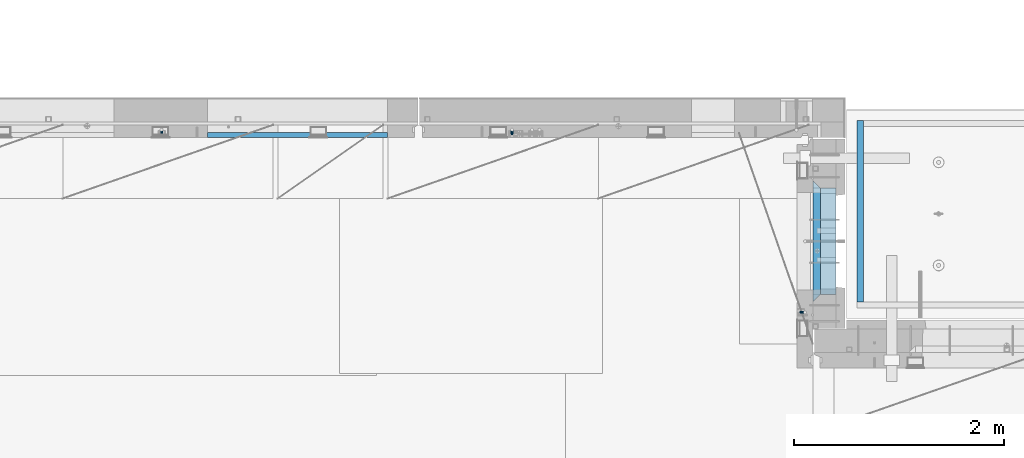
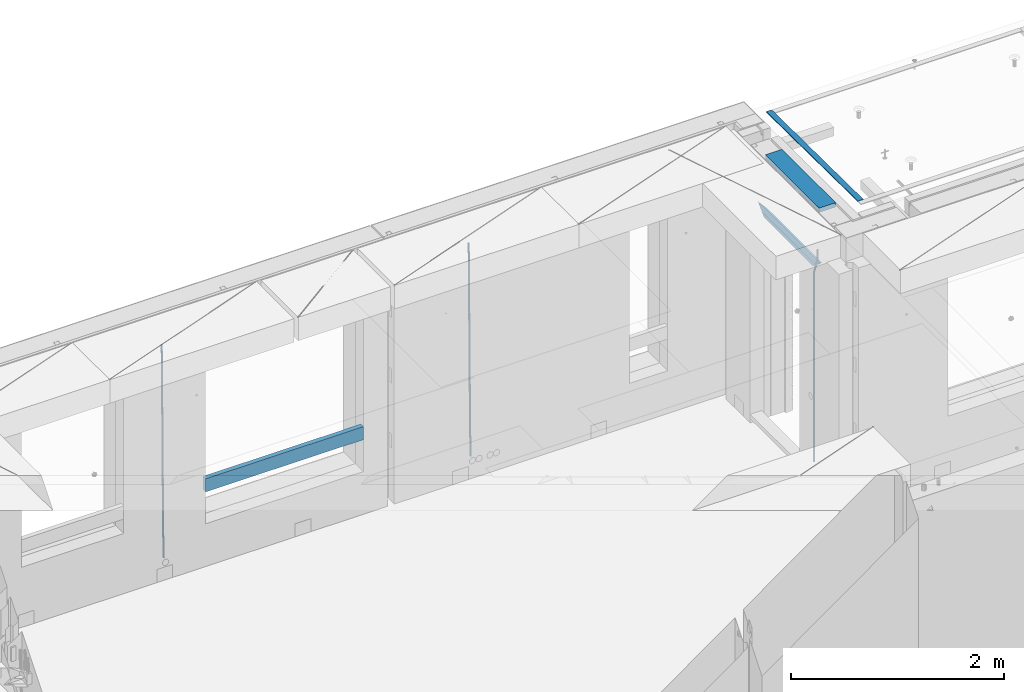
# One storey, part 109 of 325: 8 beams, 4 elements without a shape of their own.
"""IFC2X3 building model written with IfcOpenShell, lengths in millimetres."""

from ifc_helpers import new_model, si_unit, frame, origin_with_axes, place, context, subcontext, project, spatial, faceted_brep, material, type_object, element, aggregate, save


model = new_model("IFC2X3")

# Units and contexts
model_context = context("Model", 3, precision=1e-05, world=origin_with_axes())
body_context = subcontext(model_context, "Body", "Model", "MODEL_VIEW")
ifc_project = project(units=[si_unit("LENGTHUNIT", "METRE", prefix="MILLI"), si_unit("AREAUNIT", "SQUARE_METRE"), si_unit("VOLUMEUNIT", "CUBIC_METRE"), si_unit("MASSUNIT", "GRAM", prefix="KILO"), si_unit("TIMEUNIT", "SECOND"), si_unit("PLANEANGLEUNIT", "RADIAN"), si_unit("SOLIDANGLEUNIT", "STERADIAN"), si_unit("THERMODYNAMICTEMPERATUREUNIT", "DEGREE_CELSIUS"), si_unit("LUMINOUSINTENSITYUNIT", "LUMEN")], contexts=[model_context])

# Site, building, storey
site_placement = place(None, origin_with_axes())
site = spatial("IfcSite", under=ifc_project, at=site_placement, CompositionType="ELEMENT")
building_placement = place(site_placement, origin_with_axes())
building = spatial("IfcBuilding", under=site, at=building_placement, CompositionType="ELEMENT")
storey_placement = place(building_placement, origin_with_axes())
storey = spatial("IfcBuildingStorey", under=building, at=storey_placement, Name="1", CompositionType="ELEMENT", Elevation=0.0)

# Assembly, beams
assembly_1_placement = place(storey_placement, origin_with_axes())
assembly_1 = element("IfcElementAssembly", 1, at=assembly_1_placement, inside=storey, AssemblyPlace="NOTDEFINED", PredefinedType="REINFORCEMENT_UNIT")
ifc_material_1 = material(Name="CONCRETE/C25/30")
beam_type_1 = type_object("IfcBeamType", PredefinedType="NOTDEFINED")
beam_1_placement = place(assembly_1_placement, frame((31494.9951872276, 21060.0002716511, 84140.0), z_axis=(0.0, 0.0, -1.0), x_axis=(0.0, 1.0, 0.0)))
beam_1 = element("IfcBeam", 2, at=beam_1_placement, type_object=beam_type_1, material=ifc_material_1, Name="SK", context=body_context, shape_type="Brep", body=[
    faceted_brep([(70.0000000000164, -35.0, 35.0), (70.0000000000164, 35.0, 35.0), (0.0, -35.0, -35.0), (1079.99961853027, 35.0, 35.0), (1149.99961853027, -35.0, -35.0), (1079.99961853027, -35.0, 35.0)], [[[0, 1, 2]], [[2, 1, 3, 4]], [[0, 2, 4, 5]], [[1, 0, 5, 3]], [[4, 3, 5]]]),
])
beam_type_2 = type_object("IfcBeamType", PredefinedType="NOTDEFINED")
beam_2_placement = place(assembly_1_placement, frame((31494.9951872276, 21130.0002716511, 84080.0), z_axis=(0.0, 0.0, -1.0), x_axis=(0.0, 1.0, 0.0)))
beam_2 = element("IfcBeam", 3, at=beam_2_placement, type_object=beam_type_2, material=ifc_material_1, Name="SK", context=body_context, shape_type="Brep", body=[
    faceted_brep([(0.0, -35.0, -25.0), (43.8457723764295, -35.0, 18.8461538461561), (45.6406441713007, 35.0, 20.6410256410309), (0.0, 35.0, -25.0), (1009.99961853027, 35.0, -25.0), (1009.99961853027, -35.0, -25.0), (966.153464684117, -35.0, 18.8461538461561), (964.358592889246, 35.0, 20.6410256410309)], [[[0, 1, 2, 3]], [[0, 3, 4, 5]], [[1, 0, 5, 6]], [[6, 7, 2, 1]], [[3, 2, 7, 4]], [[6, 5, 4, 7]]]),
])
ifc_material_2 = material()
beam_type_3 = type_object("IfcBeamType", Name="D20", PredefinedType="NOTDEFINED")
beam_3_placement = place(assembly_1_placement, frame((31384.9951872298, 20959.9999999916, 84407.5), z_axis=(-0.999999913638316, 0.000415599999849952, 0.0), x_axis=(0.0, 0.0, -1.0)))
beam_3 = element("IfcBeam", 4, at=beam_3_placement, type_object=beam_type_3, material=ifc_material_2, Name="JM20", ObjectType="D20", context=body_context, shape_type="Brep", body=[
    faceted_brep([(0.0, -10.0, 0.0), (-4.19531716033816e-08, -7.07106781186667, -7.07106781187031), (113.248091332178, -7.0710684840451, -7.0710678117357), (113.248091314759, -10.0000006713562, -2.51020537689328e-10), (0.0, 0.0, -10.0), (113.248091374131, -6.72178430249915e-07, -9.99999999986903), (4.196772351861e-08, 7.07106781186303, -7.07106781186667), (113.248091416113, 7.07106713968824, -7.07106781173934), (0.0, 10.0, 0.0), (113.248091433488, 9.99999932782521, 1.30967237055302e-10), (4.196772351861e-08, 7.07106781185939, 7.07106781185939), (113.248091416113, 7.0710671396846, 7.071067811994), (0.0, 0.0, 10.0), (113.248091374131, -6.72174792271107e-07, 10.0000000001273), (-4.19531716033816e-08, -7.07106781187031, 7.07106781185939), (113.248091332178, -7.0710684840451, 7.071067811994), (130.699843527167, -7.06993249763036, -4.33745683788584), (128.538066582521, -9.99900540317321, 2.39499413731755), (131.594536475241, 0.00119355250353692, -7.12624594330919), (130.698046432328, 7.07220300913468, -4.33773834422391), (128.535525107087, 10.0009944322555, 2.39459602660281), (126.373748162892, 7.07192152754578, 9.1270470011732), (125.479055214906, 0.000795477419160306, 11.9158361066184), (126.37554525779, -7.07021397921199, 9.12732850753673), (240.336258550378, -7.05529970173666, 30.8729495437874), (238.174481606227, -9.98437260450009, 37.6054005176375), (241.230951498423, 0.0158263482953771, 28.0841604381058), (240.334461455612, 7.0868358050102, 30.8726680369582), (238.171940130502, 10.0156272283348, 37.6050024077231), (236.010163186409, 7.08655432384694, 44.3374533824244), (235.115470238379, 0.0154282738185429, 47.1262424881097), (236.011960281176, -7.05558118289991, 44.3377348892536), (253.461915329972, -7.05444528127919, 32.9289287376414), (253.46191532613, -9.98337746617108, 39.9999965521893), (253.461915339081, 0.0166225284556276, 29.9999965443676), (253.461915348205, 7.08769034247234, 32.9289287273205), (253.461915352003, 10.0166225357716, 39.9999965370152), (253.461915348293, 7.08769035281148, 47.0710643509774), (253.461915339183, 0.0166225430875784, 49.999996544273), (253.46191533003, -7.05444527093641, 47.0710643613093), (2417.50000002384, -7.0544364694706, 32.9289287374122), (2417.5000000337, -9.98336865393321, 39.9999965507959), (2417.49999999997, 0.0166313408753922, 29.9999965456082), (2417.49999997609, 7.08769915426274, 32.9289287300708), (2417.4999999662, 10.0166313460668, 39.9999965404204), (2417.49999997608, 7.08769916160054, 47.0710643538114), (2417.49999999994, 0.0166313512581837, 49.9999965456154), (2417.50000002382, -7.05443646212916, 47.0710643611455)], [[[0, 1, 2, 3]], [[1, 4, 5, 2]], [[4, 6, 7, 5]], [[6, 8, 9, 7]], [[8, 10, 11, 9]], [[10, 12, 13, 11]], [[12, 14, 15, 13]], [[14, 0, 3, 15]], [[14, 12, 10, 8, 6, 4, 1, 0]], [[3, 2, 16, 17]], [[2, 5, 18, 16]], [[5, 7, 19, 18]], [[7, 9, 20, 19]], [[9, 11, 21, 20]], [[11, 13, 22, 21]], [[13, 15, 23, 22]], [[15, 3, 17, 23]], [[17, 16, 24, 25]], [[16, 18, 26, 24]], [[18, 19, 27, 26]], [[19, 20, 28, 27]], [[20, 21, 29, 28]], [[21, 22, 30, 29]], [[22, 23, 31, 30]], [[23, 17, 25, 31]], [[25, 24, 32, 33]], [[24, 26, 34, 32]], [[26, 27, 35, 34]], [[27, 28, 36, 35]], [[28, 29, 37, 36]], [[29, 30, 38, 37]], [[30, 31, 39, 38]], [[31, 25, 33, 39]], [[33, 32, 40, 41]], [[32, 34, 42, 40]], [[34, 35, 43, 42]], [[35, 36, 44, 43]], [[36, 37, 45, 44]], [[37, 38, 46, 45]], [[38, 39, 47, 46]], [[39, 33, 41, 47]], [[42, 43, 44, 45, 46, 47, 41, 40]]]),
])

# Assembly, beam
assembly_2_placement = place(storey_placement, origin_with_axes())
assembly_2 = element("IfcElementAssembly", 5, at=assembly_2_placement, inside=storey, AssemblyPlace="NOTDEFINED", PredefinedType="REINFORCEMENT_UNIT")
beam_4_placement = place(assembly_2_placement, frame((28600.0000000039, 22654.9999977209, 81990.0), z_axis=(-0.000205762999925498, 0.999642804629538, -0.0267249099901004), x_axis=(4.30000201928125e-08, 0.0267249099948059, 0.999642825806181)))
beam_4 = element("IfcBeam", 6, at=beam_4_placement, type_object=beam_type_3, material=ifc_material_2, Name="JM20", ObjectType="D20", context=body_context, shape_type="Brep", body=[
    faceted_brep([(0.0, -10.0, 0.0), (-4.19531716033816e-08, -7.07106781186667, -7.07106781187031), (60.4266690400545, -7.0710677960451, -7.07106780570757), (60.4266690441291, -9.99999998418934, 6.15546014159918e-09), (0.0, 0.0, -10.0), (60.426669036824, 1.58106558956206e-08, -9.99999999384454), (4.196772351861e-08, 7.07106781186303, -7.07106781186667), (60.4266690363438, 7.07106782768096, -7.07106780570757), (0.0, 10.0, 0.0), (60.4266690388904, 10.0000000158179, 6.15182216279209e-09), (4.196772351861e-08, 7.07106781185939, 7.07106781185939), (60.4266690429649, 7.07106782768096, 7.07106781802577), (0.0, 0.0, 10.0), (60.4266690461809, 1.58179318532348e-08, 10.0000000061555), (-4.19531716033816e-08, -7.07106781187031, 7.07106781185939), (60.4266690466611, -7.07106779605238, 7.07106781802213), (61.0378400410118, -7.07106779588503, -7.07106780564936), (60.991799419251, -9.99999998403655, 6.21366780251265e-09), (61.0569027789461, 1.5985278878361e-08, -9.99999999378269), (61.0378209396877, 7.07106782784831, -7.07106780564936), (60.9917724058905, 10.0000000159635, 6.21366780251265e-09), (60.9457317841297, 7.07106782781193, 7.0710678180767), (60.9266690461809, 1.59488990902901e-08, 10.0000000062028), (60.9457508854539, -7.07106779591413, 7.0710678180767), (61.6489592143771, -7.07106614513759, -7.06310863441468), (61.5568818710308, -9.9999984576425, 0.00735959856683621), (61.6870830769039, 1.71821739058942e-06, -9.99179257185824), (61.6489210170112, 7.07106947854481, -7.06310888312146), (61.556827851804, 10.0000015422847, 0.00735924683976918), (61.4647505084577, 7.07106922979438, 7.07782747982128), (61.4266266459163, 1.36643211590126e-06, 10.0065114172685), (61.464788705809, -7.07106639389531, 7.07782772852806), (176.543135720174, -7.07075579406956, -5.56673531796696), (176.451058376813, -9.99968810657447, 1.50373291501455), (176.581259582701, 0.000312069292704109, -8.49541925541052), (176.543097522794, 7.07137982961285, -5.56673556667374), (176.451004357587, 10.00031189336, 1.50373256329476), (176.35892701424, 7.07137958085514, 8.57420079627263), (176.320803151699, 0.000311717507429421, 11.5028847337162), (176.358965211621, -7.07075604281999, 8.57420104497578), (177.098753836006, -7.07075429323595, -5.55949898843028), (176.98362511232, -9.99968666800123, 1.510669025065), (177.146421932586, 0.000313595905026887, -8.48805862247536), (177.098706077581, 7.07138133041735, -5.55949936166144), (176.983557571715, 10.0003133318824, 1.51066849724157), (176.868428848029, 7.07138095712435, 8.58083651073321), (176.820760751449, 0.000313067976094317, 11.5093961447819), (176.868476606425, -7.07075466652896, 8.58083688396073), (177.654312950661, -7.07075204110879, -5.54863964998367), (177.516135294456, -9.99968450931192, 1.52107783331303), (177.711524267797, 0.000315886711177882, -8.47701274570863), (177.654255632195, 7.07138358250813, -5.54864021007961), (177.516054233929, 10.0003154905207, 1.5210770412159), (177.377876577739, 7.0713830223176, 8.59079452451624), (177.320665260588, 0.000315094497636892, 11.5191676202448), (177.377933896176, -7.07075260129932, 8.59079508461218), (299.436796249574, -7.07025836271714, -3.1681962331204), (299.298618593355, -9.99919083092027, 3.90152125031091), (299.494007566798, 0.000809565110102994, -6.09656932889993), (299.436738931283, 7.07187726089978, -3.16819679320906), (299.298537533061, 10.0008091689197, 3.90152045822106), (299.160359876842, 7.07187670072017, 10.9712379416487), (299.103148559603, 0.000808772889286047, 13.8996110374392), (299.160417195119, -7.07025892290039, 10.9712385017483), (299.98743051647, -7.07025613056248, -3.15743315966392), (299.971788958996, -9.99918809853989, 3.91467979818117), (299.993912075952, 0.000811591617093654, -6.08679785393178), (299.987423933868, 7.07187949325817, -3.1574327280432), (299.971753863239, 10.0008119014747, 3.91467990454839), (299.95611230444, 7.07187992653053, 10.9867922621015), (299.949630744944, 0.000812204350950196, 13.9161569563694), (299.956118887014, -7.07025569729012, 10.9867918304735), (300.538107039494, -7.07025785017686, -3.16575821840888), (300.644985195438, -9.99919020432935, 3.90450175465594), (300.493854948218, 0.000810030429420294, -6.09435592770024), (300.538151196495, 7.071877773491, -3.16575855385963), (300.645047642858, 10.0008097955724, 3.90450128024895), (300.751925798773, 7.07187744142357, 10.9747612533101), (300.796177890064, 0.000809560813650023, 13.9033589625978), (300.751881641787, -7.07025818224065, 10.9747615887682), (2293.36490490142, -7.07648090940347, -33.2930642912361), (2293.47178305736, -10.0054132635523, -26.2228043181785), (2293.32065281013, -0.00541302880083094, -36.2216620005347), (2293.36494905842, 7.06565471425711, -33.2930646266868), (2293.47184550477, 9.99458673634581, -26.2228047925819), (2293.57872366071, 7.06565438219332, -19.1525448195243), (2293.62297575199, -0.00541349841296324, -16.2239471102366), (2293.57867950371, -7.0764812414709, -19.1525444840736), (2294.0658245362, -7.07648309818615, -33.3036607065333), (2294.05312277409, -10.0054150789219, -26.2315929392535), (2294.10928714235, -0.00541549149056664, -36.2335844756526), (2294.15805078732, 7.06565223761572, -33.3050546393533), (2294.18355038921, 9.99458451388637, -26.2335642579346), (2294.17084862708, 7.06565253314329, -19.1614964906439), (2294.12738602093, -0.00541507354500936, -16.2315727215355), (2294.07862237596, -7.07648280265857, -19.1601025578348), (2294.76670261032, -7.08562269121467, -33.294332712383), (2294.63442802057, -10.0129954178956, -26.2238563411993), (2294.89787471293, -0.0156988342423574, -36.2230891548279), (2294.95110548967, 7.05531064255774, -33.2944998654275), (2294.89521307347, 9.98530428734011, -26.2240927312887), (2294.76293848372, 7.0579315606592, -19.1536163601049), (2294.63176638114, -0.0119922963167483, -16.2248599176673), (2294.57853560438, -7.08300177311321, -19.1534492070678), (2316.52657204497, -7.36937582653991, -33.0047303660212), (2316.39429745522, -10.2967485532172, -25.9342539948302), (2316.65774414754, -0.299451969567599, -35.9334868084661), (2316.7109749243, 6.7715575072325, -33.0048975190657), (2316.65508250811, 9.70155115201487, -25.9344903849269), (2316.52280791836, 6.7741784253376, -18.8640140137468), (2316.39163581574, -0.295745431634714, -15.9352575713092), (2316.33840503903, -7.36675490843481, -18.863846860706), (2317.16202064224, -7.37766220584308, -32.9962731735213), (2317.05438744847, -10.3053562613532, -25.9254688497131), (2317.23607125619, -0.306993473008333, -35.925789846493), (2317.23316144495, 6.76474808850253, -32.9979477328052), (2317.15499573652, 9.6950321815566, -25.9278370341635), (2317.04736254275, 6.7673381260538, -18.8570327103698), (2316.97331192881, -0.303330606784584, -15.9275160373909), (2316.97622174003, -7.37507216829545, -18.8553581510787), (2317.79752306276, -7.37578610372293, -32.9880110666527), (2317.71453320107, -10.3033876998124, -25.9168792378296), (2317.81444760226, -0.305295583297266, -35.918287695793), (2317.75539265381, 6.76628640723357, -32.9911928173897), (2317.65495180529, 9.69652304524061, -25.9213789128698), (2317.5719619436, 6.76892144914746, -18.8502470840467), (2317.55503740412, -0.301569071270933, -15.9199704549137), (2317.61409235255, -7.3731510618054, -18.847065333317), (2417.8183084176, -7.07752398473531, -31.6906369377139), (2417.73531855589, -10.0051255808248, -24.6195051088798), (2417.83523295709, -0.007033464313281, -34.6209135668432), (2417.77617800863, 7.06454852621755, -31.6938186884508), (2417.67573716014, 9.99478516423187, -24.6240047839383), (2417.59274729842, 7.06718356813872, -17.5528729551006), (2417.57582275895, -0.00330695228694822, -14.6225963259749), (2417.6348777074, -7.07488894281778, -17.5496912043673)], [[[0, 1, 2, 3]], [[1, 4, 5, 2]], [[4, 6, 7, 5]], [[6, 8, 9, 7]], [[8, 10, 11, 9]], [[10, 12, 13, 11]], [[12, 14, 15, 13]], [[14, 0, 3, 15]], [[14, 12, 10, 8, 6, 4, 1, 0]], [[3, 2, 16, 17]], [[2, 5, 18, 16]], [[5, 7, 19, 18]], [[7, 9, 20, 19]], [[9, 11, 21, 20]], [[11, 13, 22, 21]], [[13, 15, 23, 22]], [[15, 3, 17, 23]], [[17, 16, 24, 25]], [[16, 18, 26, 24]], [[18, 19, 27, 26]], [[19, 20, 28, 27]], [[20, 21, 29, 28]], [[21, 22, 30, 29]], [[22, 23, 31, 30]], [[23, 17, 25, 31]], [[25, 24, 32, 33]], [[24, 26, 34, 32]], [[26, 27, 35, 34]], [[27, 28, 36, 35]], [[28, 29, 37, 36]], [[29, 30, 38, 37]], [[30, 31, 39, 38]], [[31, 25, 33, 39]], [[33, 32, 40, 41]], [[32, 34, 42, 40]], [[34, 35, 43, 42]], [[35, 36, 44, 43]], [[36, 37, 45, 44]], [[37, 38, 46, 45]], [[38, 39, 47, 46]], [[39, 33, 41, 47]], [[41, 40, 48, 49]], [[40, 42, 50, 48]], [[42, 43, 51, 50]], [[43, 44, 52, 51]], [[44, 45, 53, 52]], [[45, 46, 54, 53]], [[46, 47, 55, 54]], [[47, 41, 49, 55]], [[49, 48, 56, 57]], [[48, 50, 58, 56]], [[50, 51, 59, 58]], [[51, 52, 60, 59]], [[52, 53, 61, 60]], [[53, 54, 62, 61]], [[54, 55, 63, 62]], [[55, 49, 57, 63]], [[57, 56, 64, 65]], [[56, 58, 66, 64]], [[58, 59, 67, 66]], [[59, 60, 68, 67]], [[60, 61, 69, 68]], [[61, 62, 70, 69]], [[62, 63, 71, 70]], [[63, 57, 65, 71]], [[65, 64, 72, 73]], [[64, 66, 74, 72]], [[66, 67, 75, 74]], [[67, 68, 76, 75]], [[68, 69, 77, 76]], [[69, 70, 78, 77]], [[70, 71, 79, 78]], [[71, 65, 73, 79]], [[73, 72, 80, 81]], [[72, 74, 82, 80]], [[74, 75, 83, 82]], [[75, 76, 84, 83]], [[76, 77, 85, 84]], [[77, 78, 86, 85]], [[78, 79, 87, 86]], [[79, 73, 81, 87]], [[81, 80, 88, 89]], [[80, 82, 90, 88]], [[82, 83, 91, 90]], [[83, 84, 92, 91]], [[84, 85, 93, 92]], [[85, 86, 94, 93]], [[86, 87, 95, 94]], [[87, 81, 89, 95]], [[89, 88, 96, 97]], [[88, 90, 98, 96]], [[90, 91, 99, 98]], [[91, 92, 100, 99]], [[92, 93, 101, 100]], [[93, 94, 102, 101]], [[94, 95, 103, 102]], [[95, 89, 97, 103]], [[97, 96, 104, 105]], [[96, 98, 106, 104]], [[98, 99, 107, 106]], [[99, 100, 108, 107]], [[100, 101, 109, 108]], [[101, 102, 110, 109]], [[102, 103, 111, 110]], [[103, 97, 105, 111]], [[105, 104, 112, 113]], [[104, 106, 114, 112]], [[106, 107, 115, 114]], [[107, 108, 116, 115]], [[108, 109, 117, 116]], [[109, 110, 118, 117]], [[110, 111, 119, 118]], [[111, 105, 113, 119]], [[113, 112, 120, 121]], [[112, 114, 122, 120]], [[114, 115, 123, 122]], [[115, 116, 124, 123]], [[116, 117, 125, 124]], [[117, 118, 126, 125]], [[118, 119, 127, 126]], [[119, 113, 121, 127]], [[121, 120, 128, 129]], [[120, 122, 130, 128]], [[122, 123, 131, 130]], [[123, 124, 132, 131]], [[124, 125, 133, 132]], [[125, 126, 134, 133]], [[126, 127, 135, 134]], [[127, 121, 129, 135]], [[130, 131, 132, 133, 134, 135, 129, 128]]]),
])
aggregate(assembly_2, [beam_4])

# Assembly, beams
assembly_3_placement = place(storey_placement, origin_with_axes())
assembly_3 = element("IfcElementAssembly", 7, at=assembly_3_placement, inside=storey, AssemblyPlace="NOTDEFINED", PredefinedType="REINFORCEMENT_UNIT")
beam_5_placement = place(assembly_3_placement, frame((25270.0000000039, 22654.999995444, 81990.0), z_axis=(-0.000205762999925498, 0.999642804629538, -0.0267249099901004), x_axis=(4.30000201928125e-08, 0.0267249099948059, 0.999642825806181)))
beam_5 = element("IfcBeam", 8, at=beam_5_placement, type_object=beam_type_3, material=ifc_material_2, Name="JM20", ObjectType="D20", context=body_context, shape_type="Brep", body=[
    faceted_brep([(0.0, -10.0, 0.0), (-4.19531716033816e-08, -7.07106781186667, -7.07106781187031), (60.4266690400545, -7.0710677960451, -7.07106780570757), (60.4266690441291, -9.99999998418934, 6.15546014159918e-09), (0.0, 0.0, -10.0), (60.426669036824, 1.58106558956206e-08, -9.99999999384454), (4.196772351861e-08, 7.07106781186303, -7.07106781186667), (60.4266690363438, 7.07106782768096, -7.07106780570757), (0.0, 10.0, 0.0), (60.4266690388904, 10.0000000158179, 6.15182216279209e-09), (4.196772351861e-08, 7.07106781185939, 7.07106781185939), (60.4266690429649, 7.07106782768096, 7.07106781802577), (0.0, 0.0, 10.0), (60.4266690461809, 1.58179318532348e-08, 10.0000000061555), (-4.19531716033816e-08, -7.07106781187031, 7.07106781185939), (60.4266690466611, -7.07106779605238, 7.07106781802213), (61.0378400410118, -7.07106779588503, -7.07106780564936), (60.991799419251, -9.99999998403655, 6.21366780251265e-09), (61.0569027789461, 1.5985278878361e-08, -9.99999999378269), (61.0378209396877, 7.07106782784831, -7.07106780564936), (60.9917724058905, 10.0000000159635, 6.21366780251265e-09), (60.9457317841297, 7.07106782781193, 7.0710678180767), (60.9266690461809, 1.59488990902901e-08, 10.0000000062028), (60.9457508854539, -7.07106779591413, 7.0710678180767), (61.6489592143771, -7.07106614513759, -7.06310863441468), (61.5568818710308, -9.9999984576425, 0.00735959856683621), (61.6870830769039, 1.71821739058942e-06, -9.99179257185824), (61.6489210170112, 7.07106947854481, -7.06310888312146), (61.556827851804, 10.0000015422847, 0.00735924683976918), (61.4647505084577, 7.07106922979438, 7.07782747982128), (61.4266266459163, 1.36643211590126e-06, 10.0065114172685), (61.464788705809, -7.07106639389531, 7.07782772852806), (176.543135720174, -7.07075579406956, -5.56673531796696), (176.451058376813, -9.99968810657447, 1.50373291501455), (176.581259582701, 0.000312069292704109, -8.49541925541052), (176.543097522794, 7.07137982961285, -5.56673556667374), (176.451004357587, 10.00031189336, 1.50373256329476), (176.35892701424, 7.07137958085514, 8.57420079627263), (176.320803151699, 0.000311717507429421, 11.5028847337162), (176.358965211621, -7.07075604281999, 8.57420104497578), (177.098753836006, -7.07075429323595, -5.55949898843028), (176.98362511232, -9.99968666800123, 1.510669025065), (177.146421932586, 0.000313595905026887, -8.48805862247536), (177.098706077581, 7.07138133041735, -5.55949936166144), (176.983557571715, 10.0003133318824, 1.51066849724157), (176.868428848029, 7.07138095712435, 8.58083651073321), (176.820760751449, 0.000313067976094317, 11.5093961447819), (176.868476606425, -7.07075466652896, 8.58083688396073), (177.654312950661, -7.07075204110879, -5.54863964998367), (177.516135294456, -9.99968450931192, 1.52107783331303), (177.711524267797, 0.000315886711177882, -8.47701274570863), (177.654255632195, 7.07138358250813, -5.54864021007961), (177.516054233929, 10.0003154905207, 1.5210770412159), (177.377876577739, 7.0713830223176, 8.59079452451624), (177.320665260588, 0.000315094497636892, 11.5191676202448), (177.377933896176, -7.07075260129932, 8.59079508461218), (299.436796249574, -7.07025836271714, -3.1681962331204), (299.298618593355, -9.99919083092027, 3.90152125031091), (299.494007566798, 0.000809565110102994, -6.09656932889993), (299.436738931283, 7.07187726089978, -3.16819679320906), (299.298537533061, 10.0008091689197, 3.90152045822106), (299.160359876842, 7.07187670072017, 10.9712379416487), (299.103148559603, 0.000808772889286047, 13.8996110374392), (299.160417195119, -7.07025892290039, 10.9712385017483), (299.98743051647, -7.07025613056248, -3.15743315966392), (299.971788958996, -9.99918809853989, 3.91467979818117), (299.993912075952, 0.000811591617093654, -6.08679785393178), (299.987423933868, 7.07187949325817, -3.1574327280432), (299.971753863239, 10.0008119014747, 3.91467990454839), (299.95611230444, 7.07187992653053, 10.9867922621015), (299.949630744944, 0.000812204350950196, 13.9161569563694), (299.956118887014, -7.07025569729012, 10.9867918304735), (300.538107039494, -7.07025785017686, -3.16575821840888), (300.644985195438, -9.99919020432935, 3.90450175465594), (300.493854948218, 0.000810030429420294, -6.09435592770024), (300.538151196495, 7.071877773491, -3.16575855385963), (300.645047642858, 10.0008097955724, 3.90450128024895), (300.751925798773, 7.07187744142357, 10.9747612533101), (300.796177890064, 0.000809560813650023, 13.9033589625978), (300.751881641787, -7.07025818224065, 10.9747615887682), (2293.36490490142, -7.07648090940347, -33.2930642912361), (2293.47178305736, -10.0054132635523, -26.2228043181785), (2293.32065281013, -0.00541302880083094, -36.2216620005347), (2293.36494905842, 7.06565471425711, -33.2930646266868), (2293.47184550477, 9.99458673634581, -26.2228047925819), (2293.57872366071, 7.06565438219332, -19.1525448195243), (2293.62297575199, -0.00541349841296324, -16.2239471102366), (2293.57867950371, -7.0764812414709, -19.1525444840736), (2294.0658245362, -7.07648309818615, -33.3036607065333), (2294.05312277409, -10.0054150789219, -26.2315929392535), (2294.10928714235, -0.00541549149056664, -36.2335844756526), (2294.15805078732, 7.06565223761572, -33.3050546393533), (2294.18355038921, 9.99458451388637, -26.2335642579346), (2294.17084862708, 7.06565253314329, -19.1614964906439), (2294.12738602093, -0.00541507354500936, -16.2315727215355), (2294.07862237596, -7.07648280265857, -19.1601025578348), (2294.76670261032, -7.08562269121467, -33.294332712383), (2294.63442802057, -10.0129954178956, -26.2238563411993), (2294.89787471293, -0.0156988342423574, -36.2230891548279), (2294.95110548967, 7.05531064255774, -33.2944998654275), (2294.89521307347, 9.98530428734011, -26.2240927312887), (2294.76293848372, 7.0579315606592, -19.1536163601049), (2294.63176638114, -0.0119922963167483, -16.2248599176673), (2294.57853560438, -7.08300177311321, -19.1534492070678), (2316.52657204497, -7.36937582653991, -33.0047303660212), (2316.39429745522, -10.2967485532172, -25.9342539948302), (2316.65774414754, -0.299451969567599, -35.9334868084661), (2316.7109749243, 6.7715575072325, -33.0048975190657), (2316.65508250811, 9.70155115201487, -25.9344903849269), (2316.52280791836, 6.7741784253376, -18.8640140137468), (2316.39163581574, -0.295745431634714, -15.9352575713092), (2316.33840503903, -7.36675490843481, -18.863846860706), (2317.16202064224, -7.37766220584308, -32.9962731735213), (2317.05438744847, -10.3053562613532, -25.9254688497131), (2317.23607125619, -0.306993473008333, -35.925789846493), (2317.23316144495, 6.76474808850253, -32.9979477328052), (2317.15499573652, 9.6950321815566, -25.9278370341635), (2317.04736254275, 6.7673381260538, -18.8570327103698), (2316.97331192881, -0.303330606784584, -15.9275160373909), (2316.97622174003, -7.37507216829545, -18.8553581510787), (2317.79752306276, -7.37578610372293, -32.9880110666527), (2317.71453320107, -10.3033876998124, -25.9168792378296), (2317.81444760226, -0.305295583297266, -35.918287695793), (2317.75539265381, 6.76628640723357, -32.9911928173897), (2317.65495180529, 9.69652304524061, -25.9213789128698), (2317.5719619436, 6.76892144914746, -18.8502470840467), (2317.55503740412, -0.301569071270933, -15.9199704549137), (2317.61409235255, -7.3731510618054, -18.847065333317), (2417.8183084176, -7.07752398473531, -31.6906369377139), (2417.73531855589, -10.0051255808248, -24.6195051088798), (2417.83523295709, -0.007033464313281, -34.6209135668432), (2417.77617800863, 7.06454852621755, -31.6938186884508), (2417.67573716014, 9.99478516423187, -24.6240047839383), (2417.59274729842, 7.06718356813872, -17.5528729551006), (2417.57582275895, -0.00330695228694822, -14.6225963259749), (2417.6348777074, -7.07488894281778, -17.5496912043673)], [[[0, 1, 2, 3]], [[1, 4, 5, 2]], [[4, 6, 7, 5]], [[6, 8, 9, 7]], [[8, 10, 11, 9]], [[10, 12, 13, 11]], [[12, 14, 15, 13]], [[14, 0, 3, 15]], [[14, 12, 10, 8, 6, 4, 1, 0]], [[3, 2, 16, 17]], [[2, 5, 18, 16]], [[5, 7, 19, 18]], [[7, 9, 20, 19]], [[9, 11, 21, 20]], [[11, 13, 22, 21]], [[13, 15, 23, 22]], [[15, 3, 17, 23]], [[17, 16, 24, 25]], [[16, 18, 26, 24]], [[18, 19, 27, 26]], [[19, 20, 28, 27]], [[20, 21, 29, 28]], [[21, 22, 30, 29]], [[22, 23, 31, 30]], [[23, 17, 25, 31]], [[25, 24, 32, 33]], [[24, 26, 34, 32]], [[26, 27, 35, 34]], [[27, 28, 36, 35]], [[28, 29, 37, 36]], [[29, 30, 38, 37]], [[30, 31, 39, 38]], [[31, 25, 33, 39]], [[33, 32, 40, 41]], [[32, 34, 42, 40]], [[34, 35, 43, 42]], [[35, 36, 44, 43]], [[36, 37, 45, 44]], [[37, 38, 46, 45]], [[38, 39, 47, 46]], [[39, 33, 41, 47]], [[41, 40, 48, 49]], [[40, 42, 50, 48]], [[42, 43, 51, 50]], [[43, 44, 52, 51]], [[44, 45, 53, 52]], [[45, 46, 54, 53]], [[46, 47, 55, 54]], [[47, 41, 49, 55]], [[49, 48, 56, 57]], [[48, 50, 58, 56]], [[50, 51, 59, 58]], [[51, 52, 60, 59]], [[52, 53, 61, 60]], [[53, 54, 62, 61]], [[54, 55, 63, 62]], [[55, 49, 57, 63]], [[57, 56, 64, 65]], [[56, 58, 66, 64]], [[58, 59, 67, 66]], [[59, 60, 68, 67]], [[60, 61, 69, 68]], [[61, 62, 70, 69]], [[62, 63, 71, 70]], [[63, 57, 65, 71]], [[65, 64, 72, 73]], [[64, 66, 74, 72]], [[66, 67, 75, 74]], [[67, 68, 76, 75]], [[68, 69, 77, 76]], [[69, 70, 78, 77]], [[70, 71, 79, 78]], [[71, 65, 73, 79]], [[73, 72, 80, 81]], [[72, 74, 82, 80]], [[74, 75, 83, 82]], [[75, 76, 84, 83]], [[76, 77, 85, 84]], [[77, 78, 86, 85]], [[78, 79, 87, 86]], [[79, 73, 81, 87]], [[81, 80, 88, 89]], [[80, 82, 90, 88]], [[82, 83, 91, 90]], [[83, 84, 92, 91]], [[84, 85, 93, 92]], [[85, 86, 94, 93]], [[86, 87, 95, 94]], [[87, 81, 89, 95]], [[89, 88, 96, 97]], [[88, 90, 98, 96]], [[90, 91, 99, 98]], [[91, 92, 100, 99]], [[92, 93, 101, 100]], [[93, 94, 102, 101]], [[94, 95, 103, 102]], [[95, 89, 97, 103]], [[97, 96, 104, 105]], [[96, 98, 106, 104]], [[98, 99, 107, 106]], [[99, 100, 108, 107]], [[100, 101, 109, 108]], [[101, 102, 110, 109]], [[102, 103, 111, 110]], [[103, 97, 105, 111]], [[105, 104, 112, 113]], [[104, 106, 114, 112]], [[106, 107, 115, 114]], [[107, 108, 116, 115]], [[108, 109, 117, 116]], [[109, 110, 118, 117]], [[110, 111, 119, 118]], [[111, 105, 113, 119]], [[113, 112, 120, 121]], [[112, 114, 122, 120]], [[114, 115, 123, 122]], [[115, 116, 124, 123]], [[116, 117, 125, 124]], [[117, 118, 126, 125]], [[118, 119, 127, 126]], [[119, 113, 121, 127]], [[121, 120, 128, 129]], [[120, 122, 130, 128]], [[122, 123, 131, 130]], [[123, 124, 132, 131]], [[124, 125, 133, 132]], [[125, 126, 134, 133]], [[126, 127, 135, 134]], [[127, 121, 129, 135]], [[130, 131, 132, 133, 134, 135, 129, 128]]]),
])
ifc_material_3 = material(Name="TIMBER/T24")
beam_type_4 = type_object("IfcBeamType", PredefinedType="NOTDEFINED")
beam_6_placement = place(assembly_3_placement, frame((27415.0002980493, 22644.9998418812, 82685.0), z_axis=(0.0, 0.0, 1.0), x_axis=(-1.0, 3.00000001838171e-08, 0.0)))
beam_6 = element("IfcBeam", 9, at=beam_6_placement, type_object=beam_type_4, material=ifc_material_3, context=body_context, shape_type="Brep", body=[
    faceted_brep([(-3.63797880709171e-12, 24.9999999999964, -75.0), (-3.63797880709171e-12, 24.9999999999964, 75.0), (1710.0, 25.0, 75.0), (1710.0, 25.0, -75.0), (0.0, -25.0000000000073, 75.0), (1709.99999999999, -25.0, 75.0), (0.0, -25.0000000000073, -75.0), (1709.99999999999, -25.0, -75.0)], [[[0, 1, 2, 3]], [[1, 4, 5, 2]], [[4, 6, 7, 5]], [[6, 0, 3, 7]], [[5, 7, 3, 2]], [[6, 4, 1, 0]]]),
])
aggregate(assembly_3, [beam_5, beam_6])

# Assembly, beam
assembly_4_placement = place(storey_placement, origin_with_axes())
assembly_4 = element("IfcElementAssembly", 10, at=assembly_4_placement, inside=storey, AssemblyPlace="NOTDEFINED", PredefinedType="REINFORCEMENT_UNIT")
ifc_material_4 = material(Name="CONCRETE/Concrete_Undefined")
beam_type_5 = type_object("IfcBeamType", PredefinedType="NOTDEFINED")
beam_7_placement = place(assembly_4_placement, frame((31909.9986098709, 21060.0524822207, 84725.2791116282), z_axis=(7.99999906921644e-09, 0.0107912409985276, 0.999941772863656), x_axis=(7.22999999800065e-07, 0.999941772863395, -0.0107912409985247)))
beam_7 = element("IfcBeam", 11, at=beam_7_placement, type_object=beam_type_5, material=ifc_material_4, context=body_context, shape_type="Brep", body=[
    faceted_brep([(2.5465851649642e-11, 29.9999999999982, -4.99999999998545), (-2.91038304567337e-11, 29.9999999999982, 5.0), (1725.04446838825, 29.9999999999927, 4.99999999998545), (1725.04446838825, 29.9999999999927, -5.00000000001455), (-2.5465851649642e-11, -30.0000000000018, 5.0), (1725.04446838824, -30.0000000000073, 4.99999999998545), (2.72848410531878e-11, -30.0000000000018, -4.99999999998545), (1725.04446838824, -30.0000000000073, -5.0)], [[[0, 1, 2, 3]], [[1, 4, 5, 2]], [[4, 6, 7, 5]], [[6, 0, 3, 7]], [[5, 7, 3, 2]], [[6, 4, 1, 0]]]),
])
aggregate(assembly_4, [beam_7])

# Beam
ifc_material_5 = material(Name="TIMBER")
beam_type_6 = type_object("IfcBeamType", PredefinedType="NOTDEFINED")
beam_8_placement = place(assembly_1_placement, frame((31589.9951872276, 22140.0000381475, 84715.0), z_axis=(0.0, 0.0, 1.0), x_axis=(0.0, -1.0, 0.0)))
beam_8 = element("IfcBeam", 12, at=beam_8_placement, type_object=beam_type_6, material=ifc_material_5, context=body_context, shape_type="Brep", body=[
    faceted_brep([(0.0, 90.0, -25.0), (0.0, 90.0, 25.0), (1009.99983857082, 90.0, 25.0), (1009.99983857082, 90.0, -25.0), (0.0, -90.0, 25.0), (1009.99983857082, -90.0, 25.0), (0.0, -90.0, -25.0), (1009.99983857082, -90.0, -25.0)], [[[0, 1, 2, 3]], [[1, 4, 5, 2]], [[4, 6, 7, 5]], [[6, 0, 3, 7]], [[5, 7, 3, 2]], [[6, 4, 1, 0]]]),
])

aggregate(assembly_1, [beam_3, beam_8, beam_1, beam_2])

save(model, "model.ifc")
